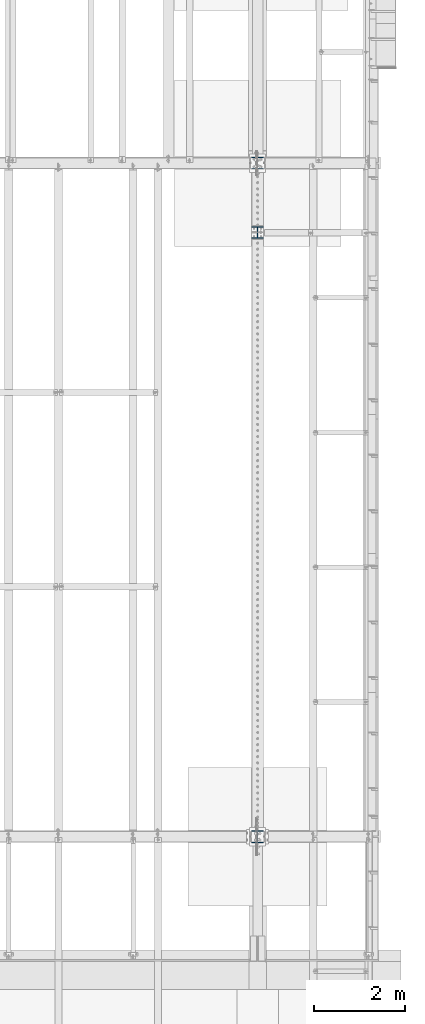
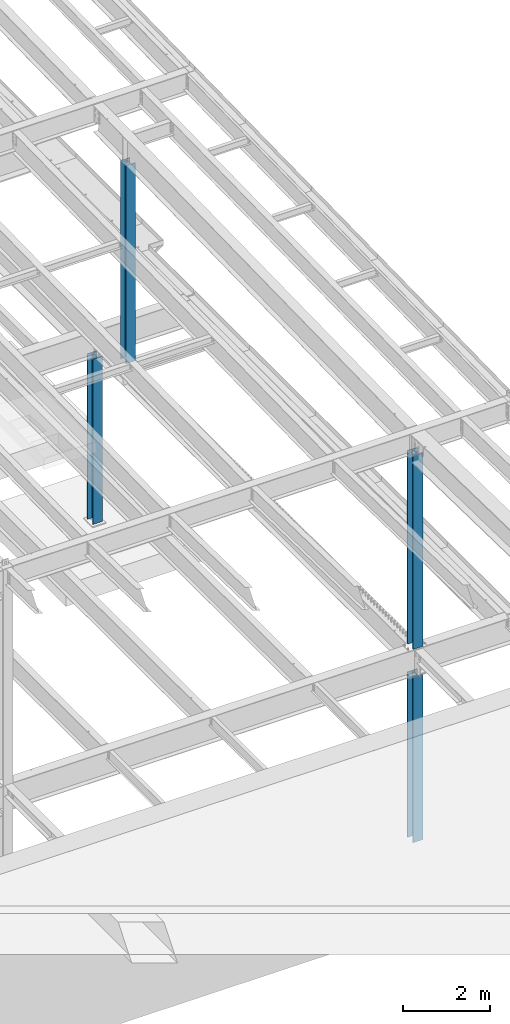
# One storey, part 912 of 1763: 4 columns, 4 elements without a shape of their own.
"""IFC2X3 building model written with IfcOpenShell, lengths in millimetres."""

from ifc_helpers import new_model, si_unit, frame, origin_with_axes, place, context, subcontext, project, spatial, faceted_brep, material, type_object, element, aggregate, save


model = new_model("IFC2X3")

# Units and contexts
model_context = context("Model", 3, precision=1e-05, world=origin_with_axes())
body_context = subcontext(model_context, "Body", "Model", "MODEL_VIEW")
ifc_project = project(units=[si_unit("LENGTHUNIT", "METRE", prefix="MILLI"), si_unit("AREAUNIT", "SQUARE_METRE"), si_unit("VOLUMEUNIT", "CUBIC_METRE"), si_unit("MASSUNIT", "GRAM", prefix="KILO"), si_unit("TIMEUNIT", "SECOND"), si_unit("PLANEANGLEUNIT", "RADIAN"), si_unit("SOLIDANGLEUNIT", "STERADIAN"), si_unit("THERMODYNAMICTEMPERATUREUNIT", "DEGREE_CELSIUS"), si_unit("LUMINOUSINTENSITYUNIT", "LUMEN")], contexts=[model_context])

# Site, building, storey
site_placement = place(None, origin_with_axes())
site = spatial("IfcSite", under=ifc_project, at=site_placement, CompositionType="ELEMENT")
building_placement = place(site_placement, origin_with_axes())
building = spatial("IfcBuilding", under=site, at=building_placement, Name="Undefined", CompositionType="ELEMENT")
storey_placement = place(building_placement, origin_with_axes())
storey = spatial("IfcBuildingStorey", under=building, at=storey_placement, Name="Undefined", CompositionType="ELEMENT", Elevation=0.0)

# Assembly, column
assembly_1_placement = place(storey_placement, origin_with_axes())
assembly_1 = element("IfcElementAssembly", 1, at=assembly_1_placement, inside=storey, Name="COLUMN", AssemblyPlace="NOTDEFINED", PredefinedType="RIGID_FRAME")
ifc_material = material(Name="STEEL/A992")
column_type_1 = type_object("IfcColumnType", Name="W10X77", PredefinedType="NOTDEFINED")
column_1_placement = place(assembly_1_placement, frame((-24027.8372736984, 30022.8, 5194.3), z_axis=(0.0, 1.0, 0.0), x_axis=(0.0, 0.0, 1.0)))
column_1 = element("IfcColumn", 2, at=column_1_placement, type_object=column_type_1, material=ifc_material, Name="COLUMN", ObjectType="W10X77", context=body_context, shape_type="Brep", body=[
    faceted_brep([(19.0499999999975, 130.174999999999, -134.9375), (19.0499999999975, 130.174999999999, -112.712500000001), (5470.52499999518, 130.174999999999, -112.712500000001), (5470.52499999518, 130.174999999999, -134.9375), (19.0499999999975, 6.34999999999854, -112.712500000001), (5470.52499999518, 6.34999999999854, -112.712500000001), (19.0499999999975, 6.34999999999854, 112.712500000001), (5470.52499999518, 6.34999999999854, 112.712500000001), (19.0499999999975, 130.174999999999, 112.712500000001), (5470.52499999518, 130.174999999999, 112.712500000001), (19.0499999999975, 130.174999999999, 134.9375), (5470.52499999518, 130.174999999999, 134.9375), (19.0499999999975, -130.174999999999, 134.9375), (5470.52499999518, -130.174999999999, 134.9375), (19.0499999999975, -130.174999999999, 112.712500000001), (5470.52499999518, -130.174999999999, 112.712500000001), (19.0499999999975, -6.34999999999854, 112.712500000001), (5470.52499999518, -6.34999999999854, 112.712500000001), (19.0499999999975, -6.34999999999854, -112.712500000001), (5470.52499999518, -6.34999999999854, -112.712500000001), (19.0499999999975, -130.174999999999, -112.712500000001), (5470.52499999518, -130.174999999999, -112.712500000001), (19.0499999999975, -130.174999999999, -134.9375), (5470.52499999518, -130.174999999999, -134.9375)], [[[0, 1, 2, 3]], [[1, 4, 5, 2]], [[4, 6, 7, 5]], [[6, 8, 9, 7]], [[8, 10, 11, 9]], [[10, 12, 13, 11]], [[12, 14, 15, 13]], [[14, 16, 17, 15]], [[16, 18, 19, 17]], [[18, 20, 21, 19]], [[20, 22, 23, 21]], [[22, 0, 3, 23]], [[5, 7, 9, 11, 13, 15, 17, 19, 21, 23, 3, 2]], [[22, 20, 18, 16, 14, 12, 10, 8, 6, 4, 1, 0]]]),
])
aggregate(assembly_1, [column_1])

assembly_2_placement = place(storey_placement, origin_with_axes())
assembly_2 = element("IfcElementAssembly", 3, at=assembly_2_placement, inside=storey, Name="COLUMN", AssemblyPlace="NOTDEFINED", PredefinedType="RIGID_FRAME")
column_2_placement = place(assembly_2_placement, frame((-24027.8372736984, 30022.8, -304.8), z_axis=(0.0, 1.0, 0.0), x_axis=(0.0, 0.0, 1.0)))
column_2 = element("IfcColumn", 4, at=column_2_placement, type_object=column_type_1, material=ifc_material, Name="COLUMN", ObjectType="W10X77", context=body_context, shape_type="Brep", body=[
    faceted_brep([(69.8499999999989, 130.174999999999, -134.9375), (69.8499999999989, 130.174999999999, -112.712500000001), (4730.75, 130.174999999999, -112.712500000001), (4730.75, 130.174999999999, -134.9375), (69.8499999999952, 6.35000000000582, -112.712500000001), (4730.75, 6.34999999999854, -112.712500000001), (69.8499999999952, 6.35000000000582, 112.712500000001), (4730.75, 6.34999999999854, 112.712500000001), (69.8499999999989, 130.174999999999, 112.712500000001), (4730.75, 130.174999999999, 112.712500000001), (69.8499999999989, 130.174999999999, 134.9375), (4730.75, 130.174999999999, 134.9375), (69.8499999999989, -130.174999999999, 134.9375), (4730.75, -130.174999999999, 134.9375), (69.8499999999989, -130.174999999999, 112.712500000001), (4730.75, -130.174999999999, 112.712500000001), (69.8499999999952, -6.35000000000582, 112.712500000001), (4730.75, -6.34999999999854, 112.712500000001), (69.8499999999952, -6.35000000000582, -112.712500000001), (4730.75, -6.34999999999854, -112.712500000001), (69.8499999999989, -130.174999999999, -112.712500000001), (4730.75, -130.174999999999, -112.712500000001), (69.8499999999989, -130.174999999999, -134.9375), (4730.75, -130.174999999999, -134.9375)], [[[0, 1, 2, 3]], [[1, 4, 5, 2]], [[4, 6, 7, 5]], [[6, 8, 9, 7]], [[8, 10, 11, 9]], [[10, 12, 13, 11]], [[12, 14, 15, 13]], [[14, 16, 17, 15]], [[16, 18, 19, 17]], [[18, 20, 21, 19]], [[20, 22, 23, 21]], [[22, 0, 3, 23]], [[5, 7, 9, 11, 13, 15, 17, 19, 21, 23, 3, 2]], [[22, 20, 18, 16, 14, 12, 10, 8, 6, 4, 1, 0]]]),
])
aggregate(assembly_2, [column_2])

assembly_3_placement = place(storey_placement, origin_with_axes())
assembly_3 = element("IfcElementAssembly", 5, at=assembly_3_placement, inside=storey, Name="COLUMN", AssemblyPlace="NOTDEFINED", PredefinedType="RIGID_FRAME")
column_type_2 = type_object("IfcColumnType", Name="W10X49", PredefinedType="NOTDEFINED")
column_3_placement = place(assembly_3_placement, frame((-24027.8372736984, 43281.6, 5194.3), z_axis=(0.0, 1.0, 0.0), x_axis=(0.0, 0.0, 1.0)))
column_3 = element("IfcColumn", 6, at=column_3_placement, type_object=column_type_2, material=ifc_material, Name="COLUMN", ObjectType="W10X49", context=body_context, shape_type="Brep", body=[
    faceted_brep([(19.0499999999993, 127.0, -127.0), (19.0499999999993, 127.0, -112.712500000001), (5599.47357928101, 127.0, -112.712500000001), (5599.17797583805, 127.0, -127.0), (19.0499999999993, 3.96875, -112.712500000001), (5599.47357928101, 3.96875, -112.712500000001), (19.0499999999993, 3.96875, 112.712500000001), (5604.13754471428, 3.96875, 112.712500000001), (19.0499999999993, 127.0, 112.712500000001), (5604.13754471428, 127.0, 112.712500000001), (19.0499999999993, 127.0, 127.0), (5604.43314815723, 127.0, 127.0), (19.0499999999993, -127.0, 127.0), (5604.43314815723, -127.0, 127.0), (19.0499999999993, -127.0, 112.712500000001), (5604.13754471428, -127.0, 112.712500000001), (19.0499999999993, -3.96875, 112.712500000001), (5604.13754471428, -3.96875, 112.712500000001), (19.0499999999993, -3.96875, -112.712500000001), (5599.47357928101, -3.96875, -112.712500000001), (19.0499999999993, -127.0, -112.712500000001), (5599.47357928101, -127.0, -112.712500000001), (19.0499999999993, -127.0, -127.0), (5599.17797583805, -127.0, -127.0)], [[[0, 1, 2, 3]], [[1, 4, 5, 2]], [[4, 6, 7, 5]], [[6, 8, 9, 7]], [[8, 10, 11, 9]], [[10, 12, 13, 11]], [[12, 14, 15, 13]], [[14, 16, 17, 15]], [[16, 18, 19, 17]], [[18, 20, 21, 19]], [[20, 22, 23, 21]], [[22, 0, 3, 23]], [[5, 7, 9, 11, 13, 15, 17, 19, 21, 23, 3, 2]], [[22, 20, 18, 16, 14, 12, 10, 8, 6, 4, 1, 0]]]),
])
aggregate(assembly_3, [column_3])

assembly_4_placement = place(storey_placement, origin_with_axes())
assembly_4 = element("IfcElementAssembly", 7, at=assembly_4_placement, inside=storey, Name="COLUMN", AssemblyPlace="NOTDEFINED", PredefinedType="RIGID_FRAME")
column_type_3 = type_object("IfcColumnType", Name="W10X68", PredefinedType="NOTDEFINED")
column_4_placement = place(assembly_4_placement, frame((-24027.8372736984, 44805.6, -304.8), z_axis=(0.0, 1.0, 0.0), x_axis=(0.0, 0.0, 1.0)))
column_4 = element("IfcColumn", 8, at=column_4_placement, type_object=column_type_3, material=ifc_material, Name="COLUMN", ObjectType="W10X68", context=body_context, shape_type="Brep", body=[
    faceted_brep([(69.8499999999952, 128.587499999994, -131.762500000001), (69.8499999999952, 128.587499999994, -112.712500000001), (4730.75, 128.587500000001, -112.712500000001), (4730.75, 128.587500000001, -131.762499999997), (69.8499999999952, 6.35000000000582, -112.712500000001), (4730.75, 6.34999999999854, -112.712500000001), (69.8499999999952, 6.35000000000582, 112.712500000001), (4730.75, 6.34999999999854, 112.712500000001), (69.8499999999952, 128.587499999994, 112.712500000001), (4730.75, 128.587500000001, 112.712500000001), (69.8499999999952, 128.587499999994, 131.762500000001), (4730.75, 128.587500000001, 131.762499999997), (69.8499999999952, -128.587499999994, 131.762500000001), (4730.75, -128.587500000001, 131.762499999997), (69.8499999999952, -128.587499999994, 112.712500000001), (4730.75, -128.587500000001, 112.712500000001), (69.8499999999952, -6.35000000000582, 112.712500000001), (4730.75, -6.34999999999854, 112.712500000001), (69.8499999999952, -6.35000000000582, -112.712500000001), (4730.75, -6.34999999999854, -112.712500000001), (69.8499999999952, -128.587499999994, -112.712500000001), (4730.75, -128.587500000001, -112.712500000001), (69.8499999999952, -128.587499999994, -131.762500000001), (4730.75, -128.587500000001, -131.762499999997)], [[[0, 1, 2, 3]], [[1, 4, 5, 2]], [[4, 6, 7, 5]], [[6, 8, 9, 7]], [[8, 10, 11, 9]], [[10, 12, 13, 11]], [[12, 14, 15, 13]], [[14, 16, 17, 15]], [[16, 18, 19, 17]], [[18, 20, 21, 19]], [[20, 22, 23, 21]], [[22, 0, 3, 23]], [[5, 7, 9, 11, 13, 15, 17, 19, 21, 23, 3, 2]], [[22, 20, 18, 16, 14, 12, 10, 8, 6, 4, 1, 0]]]),
])
aggregate(assembly_4, [column_4])

save(model, "model.ifc")
